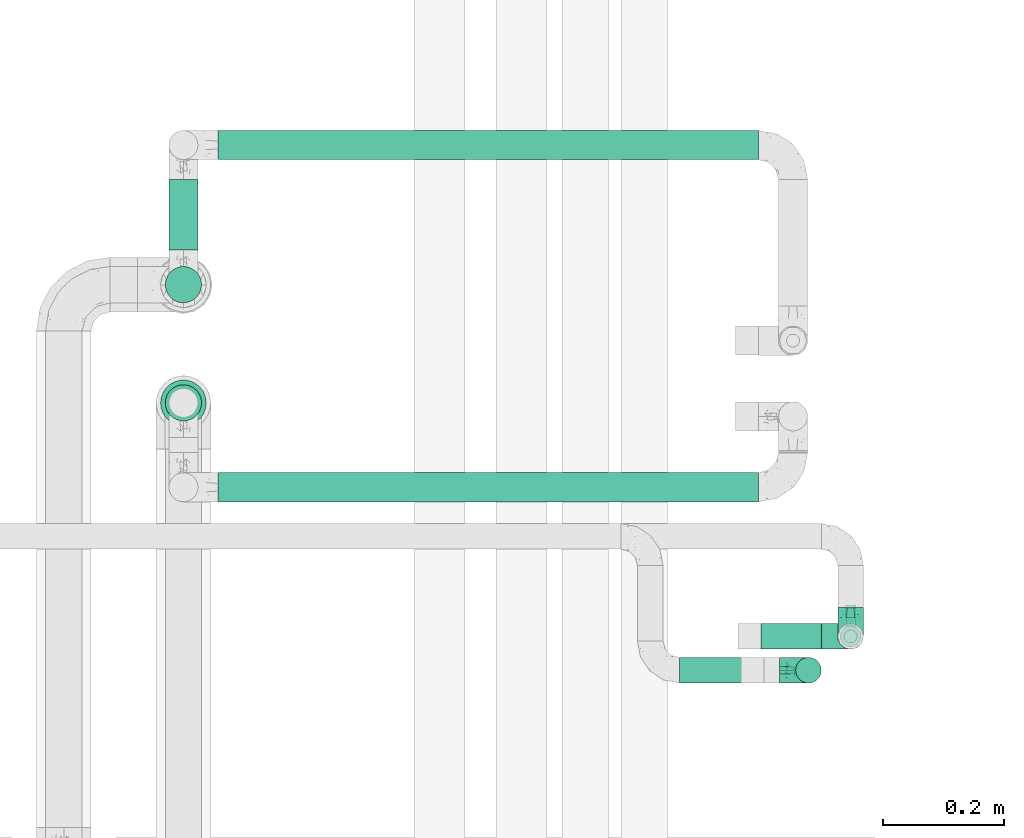
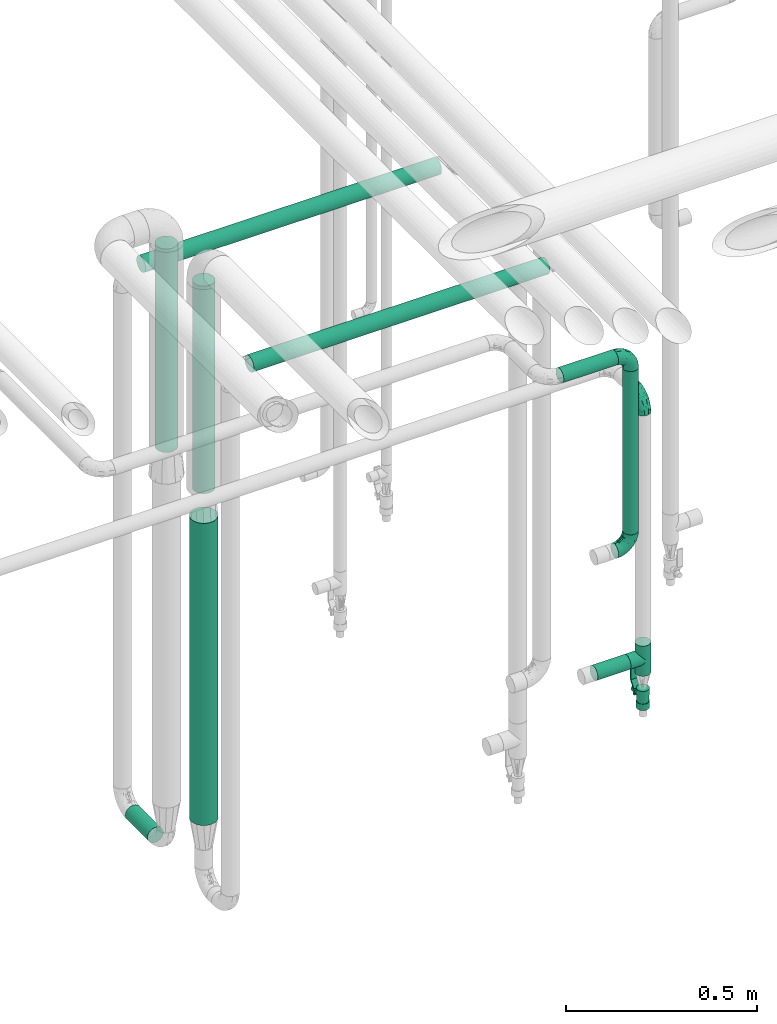
# One storey, part 575 of 827: 9 flow segments, 4 flow fittings, 1 flow controller.
"""IFC2X3 building model written with IfcOpenShell, lengths in millimetres."""

from ifc_helpers import new_model, entity, si_unit, converted_unit, derived_unit, direction, frame, origin, origin_2d_with_axis, place, context, subcontext, project, spatial, polyline, circle, outline, extrude, faceted_brep, source, transform, mapped, material, material_list, type_object, type_shapes, element, save


model = new_model("IFC2X3")

# Units and contexts
model_context = context("Model", 3, precision=0.01, world=origin(), true_north=direction((6.12303176911189e-17, 1.0)))
body_context = subcontext(model_context, "Body", "Model", "MODEL_VIEW")
ifc_project = project(units=[si_unit("LENGTHUNIT", "METRE", prefix="MILLI"), si_unit("AREAUNIT", "SQUARE_METRE"), si_unit("VOLUMEUNIT", "CUBIC_METRE"), converted_unit("PLANEANGLEUNIT", "DEGREE", entity("IfcRatioMeasure", 0.0174532925199433), si_unit("PLANEANGLEUNIT", "RADIAN"), dimensions=[0, 0, 0, 0, 0, 0, 0]), si_unit("MASSUNIT", "GRAM", prefix="KILO"), derived_unit("MASSDENSITYUNIT", [(si_unit("MASSUNIT", "GRAM", prefix="KILO"), 1), (si_unit("LENGTHUNIT", "METRE"), -3)]), derived_unit("MOMENTOFINERTIAUNIT", [(si_unit("LENGTHUNIT", "METRE"), 4)]), si_unit("TIMEUNIT", "SECOND"), si_unit("FREQUENCYUNIT", "HERTZ"), si_unit("THERMODYNAMICTEMPERATUREUNIT", "DEGREE_CELSIUS"), derived_unit("THERMALTRANSMITTANCEUNIT", [(si_unit("MASSUNIT", "GRAM", prefix="KILO"), 1), (si_unit("THERMODYNAMICTEMPERATUREUNIT", "KELVIN"), -1), (si_unit("TIMEUNIT", "SECOND"), -3)]), derived_unit("VOLUMETRICFLOWRATEUNIT", [(si_unit("LENGTHUNIT", "METRE"), 3), (si_unit("TIMEUNIT", "SECOND"), -1)]), derived_unit("MASSFLOWRATEUNIT", [(si_unit("MASSUNIT", "GRAM", prefix="KILO"), 1), (si_unit("TIMEUNIT", "SECOND"), -1)]), derived_unit("ROTATIONALFREQUENCYUNIT", [(si_unit("TIMEUNIT", "SECOND"), -1)]), si_unit("ELECTRICCURRENTUNIT", "AMPERE"), si_unit("ELECTRICVOLTAGEUNIT", "VOLT"), si_unit("POWERUNIT", "WATT"), si_unit("FORCEUNIT", "NEWTON", prefix="KILO"), si_unit("ILLUMINANCEUNIT", "LUX"), si_unit("LUMINOUSFLUXUNIT", "LUMEN"), si_unit("LUMINOUSINTENSITYUNIT", "CANDELA"), derived_unit("USERDEFINED", [(si_unit("MASSUNIT", "GRAM", prefix="KILO"), -1), (si_unit("LENGTHUNIT", "METRE"), -2), (si_unit("TIMEUNIT", "SECOND"), 3), (si_unit("LUMINOUSFLUXUNIT", "LUMEN"), 1)]), derived_unit("LINEARVELOCITYUNIT", [(si_unit("LENGTHUNIT", "METRE"), 1), (si_unit("TIMEUNIT", "SECOND"), -1)]), si_unit("PRESSUREUNIT", "PASCAL"), derived_unit("USERDEFINED", [(si_unit("LENGTHUNIT", "METRE"), -2), (si_unit("MASSUNIT", "GRAM", prefix="KILO"), 1), (si_unit("TIMEUNIT", "SECOND"), -2)]), derived_unit("LINEARFORCEUNIT", [(si_unit("MASSUNIT", "GRAM", prefix="KILO"), 1), (si_unit("LENGTHUNIT", "METRE"), 1), (si_unit("TIMEUNIT", "SECOND"), -2), (si_unit("LENGTHUNIT", "METRE"), -1)]), derived_unit("PLANARFORCEUNIT", [(si_unit("MASSUNIT", "GRAM", prefix="KILO"), 1), (si_unit("LENGTHUNIT", "METRE"), 1), (si_unit("TIMEUNIT", "SECOND"), -2), (si_unit("LENGTHUNIT", "METRE"), -2)])], contexts=[model_context])

# Site, building, storey
site_placement = place(None, origin())
site = spatial("IfcSite", under=ifc_project, at=site_placement, CompositionType="ELEMENT")
building_placement = place(site_placement, origin())
building = spatial("IfcBuilding", under=site, at=building_placement, CompositionType="ELEMENT")
storey_placement = place(building_placement, frame((0.0, 0.0, 28200.0)))
storey = spatial("IfcBuildingStorey", under=building, at=storey_placement, Name="08", CompositionType="ELEMENT", Elevation=28200.0)

# Flow segments
pipe_segment_type = type_object("IfcPipeSegmentType", PredefinedType="NOTDEFINED")
flow_segment_1_placement = place(storey_placement, frame((18741.2, 15063.0, 1977.25)))
element("IfcFlowSegment", 1, at=flow_segment_1_placement, inside=storey, type_object=pipe_segment_type, context=body_context, shape_type="SweptSolid", body=[
    extrude(circle(Radius=21.15, at=origin_2d_with_axis()), frame((0.0, 22.75, 22.75), z_axis=(1.0, 0.0, 0.0), x_axis=(0.0, -1.0, 0.0)), (0.0, 0.0, 1.0), 165.253426009053),
])
flow_segment_2_placement = place(storey_placement, frame((17890.7, 15495.65, 1662.32)))
element("IfcFlowSegment", 2, at=flow_segment_2_placement, inside=storey, type_object=pipe_segment_type, context=body_context, shape_type="SweptSolid", body=[
    extrude(circle(Radius=30.0, at=origin_2d_with_axis()), frame((31.6, 31.6, 0.0)), (0.0, 0.0, 1.0), 661.683633817541),
])
flow_segment_3_placement = place(storey_placement, frame((17890.7, 15690.85, 1675.32)))
element("IfcFlowSegment", 3, at=flow_segment_3_placement, inside=storey, type_object=pipe_segment_type, context=body_context, shape_type="SweptSolid", body=[
    extrude(circle(Radius=30.0, at=origin_2d_with_axis()), frame((31.6, 31.6, 0.0)), (0.0, 0.0, 1.0), 648.839896833194),
])
flow_segment_4_placement = place(storey_placement, frame((17896.7, 15779.44, 375.34)))
element("IfcFlowSegment", 4, at=flow_segment_4_placement, inside=storey, type_object=pipe_segment_type, context=body_context, shape_type="SweptSolid", body=[
    extrude(circle(Radius=24.0, at=origin_2d_with_axis()), frame((25.6, 0.0, 25.6), z_axis=(0.0, 1.0, 0.0), x_axis=(-1.0, 0.0, 0.0)), (0.0, 0.0, 1.0), 116.645270208734),
])
flow_segment_5_placement = place(storey_placement, frame((17979.29, 15927.49, 2070.34)))
element("IfcFlowSegment", 5, at=flow_segment_5_placement, inside=storey, type_object=pipe_segment_type, context=body_context, shape_type="SweptSolid", body=[
    extrude(circle(Radius=24.0, at=origin_2d_with_axis()), frame((0.0, 25.6, 25.6), z_axis=(1.0, 0.0, 0.0), x_axis=(0.0, -1.0, 0.0)), (0.0, 0.0, 1.0), 892.764504538315),
])
flow_segment_6_placement = place(storey_placement, frame((17979.29, 15362.39, 2095.34)))
element("IfcFlowSegment", 6, at=flow_segment_6_placement, inside=storey, type_object=pipe_segment_type, context=body_context, shape_type="SweptSolid", body=[
    extrude(circle(Radius=24.0, at=origin_2d_with_axis()), frame((0.0, 25.6, 25.6), z_axis=(1.0, 0.0, 0.0), x_axis=(0.0, -1.0, 0.0)), (0.0, 0.0, 1.0), 892.764504538304),
])
flow_segment_7_placement = place(storey_placement, frame((17882.95, 15487.9, 609.94)))
element("IfcFlowSegment", 7, at=flow_segment_7_placement, inside=storey, type_object=pipe_segment_type, context=body_context, shape_type="SweptSolid", body=[
    extrude(circle(Radius=37.75, at=origin_2d_with_axis()), frame((39.35, 39.35, 0.0), z_axis=(0.0, 0.0, 1.0), x_axis=(-1.0, 0.0, 0.0)), (0.0, 0.0, 1.0), 963.376941605387),
])
flow_segment_8_placement = place(storey_placement, frame((18931.71, 15063.0, 1431.37)))
element("IfcFlowSegment", 8, at=flow_segment_8_placement, inside=storey, type_object=pipe_segment_type, context=body_context, shape_type="SweptSolid", body=[
    extrude(circle(Radius=21.15, at=origin_2d_with_axis()), frame((22.75, 22.75, 0.0), z_axis=(0.0, 0.0, 1.0), x_axis=(-1.0, 0.0, 0.0)), (0.0, 0.0, 1.0), 520.625971677545),
])
flow_segment_9_placement = place(storey_placement, frame((18876.06, 15119.04, 947.36)))
element("IfcFlowSegment", 9, at=flow_segment_9_placement, inside=storey, type_object=pipe_segment_type, context=body_context, shape_type="SweptSolid", body=[
    extrude(circle(Radius=21.15, at=origin_2d_with_axis()), frame((0.0, 22.75, 22.75), z_axis=(1.0, 0.0, 0.0), x_axis=(0.0, 1.0, 0.0)), (0.0, 0.0, 1.0), 100.000000000001),
])

# Flow controller
ifc_material = material()
ifc_material_list = material_list([ifc_material, ifc_material, ifc_material, ifc_material, ifc_material])
valve_type = type_object("IfcValveType", PredefinedType="NOTDEFINED", material=ifc_material_list)
shared_shape_1 = source(origin(), body_context, "Body", "SweptSolid", [
    extrude(circle(Radius=17.5, at=origin_2d_with_axis()), frame((-30.5, 0.0, 0.0), z_axis=(1.0, 0.0, 0.0), x_axis=(0.0, 1.0, 0.0)), (0.0, 0.0, 1.0), 20.3333333333333),
    extrude(circle(Radius=16.0, at=origin_2d_with_axis()), frame((-10.17, 0.0, 0.0), z_axis=(1.0, 0.0, 0.0), x_axis=(0.0, 1.0, 0.0)), (0.0, 0.0, 1.0), 20.3333333333333),
    extrude(circle(Radius=17.5, at=origin_2d_with_axis()), frame((10.17, 0.0, 0.0), z_axis=(1.0, 0.0, 0.0), x_axis=(0.0, 1.0, 0.0)), (0.0, 0.0, 1.0), 20.3333333333333),
    extrude(outline(polyline([(-38.75, -5.0), (-38.75, -10.0), (-17.92, -10.0), (2.08, 5.0), (56.25, 5.0), (56.25, 10.0), (0.42, 10.0), (-19.58, -5.0), (-38.75, -5.0)])), frame((28.75, -8.75, 41.5), z_axis=(0.0, -1.0, 0.0), x_axis=(1.0, 0.0, 0.0)), (0.0, 0.0, -1.0), 17.5),
    extrude(circle(Radius=8.0, at=origin_2d_with_axis()), origin(), (0.0, 0.0, 1.0), 49.0),
])
type_shapes(valve_type, [shared_shape_1])
flow_controller_placement = place(storey_placement, frame((19024.06, 15141.79, 840.61), z_axis=(0.0, 1.0, 0.0), x_axis=(0.0, 0.0, 1.0)))
element("IfcFlowController", 10, at=flow_controller_placement, inside=storey, type_object=valve_type, material=ifc_material, context=body_context, shape_type="MappedRepresentation", body=[
    mapped(shared_shape_1, transform((0.0, 0.0, 0.0), scale=1.0)),
])

# Flow fittings
pipe_fitting_type_1 = type_object("IfcPipeFittingType", Name="ADSK_1", PredefinedType="NOTDEFINED", material=ifc_material)
shared_shape_2 = source(origin(), body_context, "Body", "Brep", [
    faceted_brep([(-48.0, 10.6, -18.36), (-48.0, 5.49, -20.48), (-48.0, 0.0, -21.2), (-48.0, -5.49, -20.48), (-48.0, -10.6, -18.36), (-48.0, -14.99, -14.99), (-48.0, -18.36, -10.6), (-48.0, -20.48, -5.49), (-48.0, -21.2, 0.0), (-48.0, -20.48, 5.49), (-48.0, -18.36, 10.6), (-48.0, -14.99, 14.99), (-48.0, -10.6, 18.36), (-48.0, -5.49, 20.48), (-48.0, 0.0, 21.2), (-48.0, 5.49, 20.48), (-48.0, 10.6, 18.36), (-48.0, 14.99, 14.99), (-48.0, 18.36, 10.6), (-48.0, 20.48, 5.49), (-48.0, 21.2, 0.0), (-48.0, 20.48, -5.49), (-48.0, 18.36, -10.6), (-48.0, 14.99, -14.99), (0.0, 48.0, -21.2), (-5.49, 48.0, -20.48), (-10.6, 48.0, -18.36), (-14.99, 48.0, -14.99), (-18.36, 48.0, -10.6), (-20.48, 48.0, -5.49), (-21.2, 48.0, 0.0), (-20.48, 48.0, 5.49), (-18.36, 48.0, 10.6), (-14.99, 48.0, 14.99), (-10.6, 48.0, 18.36), (-5.49, 48.0, 20.48), (0.0, 48.0, 21.2), (5.49, 48.0, 20.48), (10.6, 48.0, 18.36), (14.99, 48.0, 14.99), (18.36, 48.0, 10.6), (20.48, 48.0, 5.49), (21.2, 48.0, 0.0), (20.48, 48.0, -5.49), (18.36, 48.0, -10.6), (14.99, 48.0, -14.99), (10.6, 48.0, -18.36), (5.49, 48.0, -20.48), (-35.25, -16.22, 12.01), (-34.76, -18.57, 0.0), (-20.87, -12.37, 10.9), (-31.49, -11.78, 15.9), (-37.0, -2.58, 20.86), (-33.89, 3.62, 21.15), (-31.81, -18.14, 6.76), (-5.78, 5.78, 17.67), (-19.42, -4.1, 17.86), (-9.6, -3.39, 13.73), (-35.44, -7.73, 19.13), (11.78, 31.49, 15.9), (-5.93, -5.46, 6.95), (-18.45, -13.78, 5.46), (-10.29, -8.43, 0.0), (-24.6, 0.55, 20.62), (-37.28, 17.94, 13.81), (-33.38, 22.85, 9.59), (-41.46, 20.06, 8.75), (-29.51, 20.45, 15.16), (-15.04, 10.79, 21.13), (-7.08, 16.98, 20.93), (-8.39, 23.51, 21.15), (-40.86, 13.03, 17.26), (-8.05, 41.26, 19.83), (-3.21, 35.97, 21.14), (8.53, 19.66, 14.74), (4.1, 19.42, 17.86), (-37.72, 22.66, 4.78), (-37.07, 8.58, 19.98), (-13.0, 5.43, 19.97), (-3.78, 13.93, 19.7), (3.02, 8.69, 13.43), (-2.27, -0.05, 10.65), (6.22, 6.99, 7.09), (-22.25, 34.6, 9.45), (18.14, 31.81, 6.76), (16.22, 35.25, 12.01), (12.37, 20.87, 10.9), (7.73, 35.44, 19.13), (-21.52, -15.93, 0.0), (2.58, 37.0, 20.86), (18.57, 34.76, 0.0), (13.78, 18.45, 5.46), (15.93, 21.52, 0.0), (-20.03, -8.54, 14.9), (-28.6, 28.6, 5.16), (-24.79, 34.6, 0.0), (-34.6, 24.79, 0.0), (-22.81, 37.41, 4.68), (-23.36, 26.33, 14.79), (-13.68, 37.05, 17.49), (-17.72, 38.12, 13.73), (-26.25, 27.3, 11.24), (-9.71, 32.34, 20.14), (-17.26, 25.6, 18.71), (-26.33, 9.99, 20.77), (-24.06, 6.05, 21.2), (-25.02, 15.46, 19.56), (-24.3, 20.72, 17.57), (-31.95, 15.23, 17.8), (-13.53, 24.7, 20.21), (-17.6, 17.6, 20.6), (-0.55, 24.6, 20.62), (-11.41, -7.48, 10.43), (0.93, -0.93, 0.0), (8.43, 10.29, 0.0), (-11.41, -7.48, -10.43), (-20.1, -8.84, -14.66), (-9.6, -3.39, -13.73), (7.73, 35.44, -19.13), (4.1, 19.42, -17.86), (-0.55, 24.6, -20.62), (-38.12, 17.72, -13.73), (-37.05, 13.68, -17.49), (-32.34, 9.71, -20.14), (-41.26, 8.05, -19.83), (-37.41, 22.81, -4.68), (-23.51, 8.39, -21.15), (-35.97, 3.21, -21.14), (-28.6, 28.6, -5.16), (-31.81, -18.14, -6.76), (-18.45, -13.78, -5.46), (-25.6, 17.26, -18.71), (-19.42, -4.1, -17.86), (-17.94, 37.28, -13.81), (-22.85, 33.38, -9.59), (-20.06, 41.46, -8.75), (-31.49, -11.78, -15.9), (-35.25, -16.22, -12.01), (8.53, 19.66, -14.74), (11.78, 31.49, -15.9), (-9.99, 26.33, -20.77), (-6.05, 24.06, -21.2), (-10.79, 15.04, -21.13), (-37.0, -2.58, -20.86), (-16.98, 7.08, -20.93), (-5.43, 13.0, -19.97), (-13.93, 3.78, -19.7), (-20.87, -12.37, -10.9), (-26.33, 23.36, -14.79), (-22.66, 37.72, -4.78), (13.78, 18.45, -5.46), (18.14, 31.81, -6.76), (-15.46, 25.02, -19.56), (-20.72, 24.3, -17.57), (16.22, 35.25, -12.01), (-13.03, 40.86, -17.26), (-8.58, 37.07, -19.98), (2.58, 37.0, -20.86), (-3.62, 33.89, -21.15), (-34.6, 22.25, -9.45), (6.22, 6.99, -7.09), (-20.45, 29.51, -15.16), (-35.44, -7.73, -19.13), (12.37, 20.87, -10.9), (-27.3, 26.25, -11.24), (-15.23, 31.95, -17.8), (-24.7, 13.53, -20.21), (-24.6, 0.55, -20.62), (-5.78, 5.78, -17.67), (-17.6, 17.6, -20.6), (3.02, 8.69, -13.43), (-5.93, -5.46, -6.95), (-2.27, -0.05, -10.65)], [[[0, 1, 2, 3, 4, 5, 6, 7, 8, 9, 10, 11, 12, 13, 14, 15, 16, 17, 18, 19, 20, 21, 22, 23]], [[24, 25, 26, 27, 28, 29, 30, 31, 32, 33, 34, 35, 36, 37, 38, 39, 40, 41, 42, 43, 44, 45, 46, 47]], [[10, 48, 11]], [[9, 8, 49]], [[48, 50, 51]], [[14, 52, 53]], [[10, 54, 48]], [[9, 54, 10]], [[55, 56, 57]], [[51, 12, 11]], [[51, 58, 12]], [[59, 39, 38]], [[60, 61, 62]], [[58, 56, 63]], [[64, 65, 66]], [[67, 65, 64]], [[68, 69, 70]], [[16, 71, 17]], [[13, 52, 14]], [[35, 72, 73]], [[14, 53, 15]], [[17, 64, 18]], [[74, 59, 75]], [[20, 19, 76]], [[66, 19, 18]], [[77, 15, 53]], [[15, 77, 16]], [[69, 78, 79]], [[80, 81, 82]], [[32, 31, 83]], [[84, 85, 86]], [[59, 87, 75]], [[61, 54, 88]], [[36, 89, 37]], [[84, 41, 40]], [[36, 35, 73]], [[90, 41, 84]], [[40, 39, 85]], [[12, 58, 13]], [[85, 84, 40]], [[91, 84, 86]], [[84, 92, 90]], [[87, 38, 37]], [[93, 56, 51]], [[65, 94, 76]], [[94, 95, 96]], [[84, 91, 92]], [[95, 97, 30]], [[98, 99, 100]], [[76, 94, 96]], [[101, 98, 83]], [[100, 99, 33]], [[102, 70, 73]], [[103, 102, 99]], [[94, 97, 95]], [[72, 99, 102]], [[72, 35, 34]], [[34, 33, 99]], [[9, 49, 54]], [[87, 59, 38]], [[104, 105, 68]], [[106, 103, 107]], [[106, 77, 104]], [[71, 64, 17]], [[108, 107, 67]], [[33, 32, 100]], [[109, 103, 110]], [[102, 109, 70]], [[89, 73, 111]], [[50, 48, 54]], [[51, 11, 48]], [[56, 58, 51]], [[88, 54, 49]], [[52, 58, 63]], [[50, 112, 93]], [[56, 55, 78]], [[39, 59, 85]], [[86, 85, 59]], [[89, 87, 37]], [[42, 41, 90]], [[111, 79, 75]], [[111, 75, 87]], [[75, 55, 80]], [[104, 77, 53]], [[71, 77, 108]], [[32, 83, 100]], [[98, 100, 83]], [[99, 98, 103]], [[106, 107, 108]], [[68, 70, 110]], [[111, 73, 70]], [[68, 110, 104]], [[68, 63, 78]], [[57, 93, 112]], [[80, 55, 57]], [[61, 50, 54]], [[80, 82, 86]], [[81, 57, 112]], [[74, 86, 59]], [[60, 113, 82]], [[82, 114, 91]], [[101, 94, 65]], [[97, 94, 83]], [[73, 89, 36]], [[87, 89, 111]], [[58, 52, 13]], [[53, 52, 63]], [[104, 53, 105]], [[106, 104, 110]], [[20, 76, 96]], [[76, 19, 66]], [[103, 106, 110]], [[77, 106, 108]], [[103, 98, 107]], [[67, 107, 98]], [[67, 98, 101]], [[108, 67, 64]], [[53, 63, 105]], [[63, 68, 105]], [[83, 31, 97]], [[30, 97, 31]], [[62, 113, 60]], [[112, 61, 60]], [[61, 88, 62]], [[86, 82, 91]], [[56, 78, 63]], [[114, 82, 113]], [[114, 92, 91]], [[79, 78, 55]], [[75, 79, 55]], [[69, 79, 111]], [[70, 69, 111]], [[78, 69, 68]], [[77, 71, 16]], [[64, 71, 108]], [[64, 66, 18]], [[76, 66, 65]], [[99, 72, 34]], [[73, 72, 102]], [[94, 101, 83]], [[67, 101, 65]], [[75, 80, 74]], [[80, 86, 74]], [[70, 109, 110]], [[102, 103, 109]], [[50, 93, 51]], [[57, 56, 93]], [[61, 112, 50]], [[81, 112, 60]], [[82, 81, 60]], [[80, 57, 81]], [[115, 116, 117]], [[118, 119, 120]], [[121, 122, 23]], [[123, 124, 122]], [[96, 125, 20]], [[123, 126, 127]], [[128, 96, 95]], [[129, 130, 88]], [[123, 122, 131]], [[116, 132, 117]], [[133, 134, 135]], [[0, 124, 1]], [[5, 136, 137]], [[138, 119, 139]], [[129, 88, 49]], [[140, 141, 142]], [[6, 5, 137]], [[46, 118, 47]], [[143, 3, 2]], [[144, 145, 146]], [[6, 129, 7]], [[129, 137, 147]], [[127, 2, 1]], [[148, 122, 121]], [[128, 125, 96]], [[134, 128, 149]], [[95, 149, 128]], [[150, 151, 92]], [[30, 29, 149]], [[152, 131, 153]], [[27, 133, 28]], [[154, 45, 44]], [[136, 5, 4]], [[27, 26, 155]], [[156, 26, 25]], [[24, 157, 158]], [[24, 47, 157]], [[22, 21, 159]], [[160, 150, 114]], [[134, 133, 161]], [[142, 144, 126]], [[46, 139, 118]], [[162, 136, 4]], [[156, 25, 158]], [[1, 124, 127]], [[115, 147, 116]], [[45, 154, 139]], [[139, 46, 45]], [[154, 163, 139]], [[162, 4, 3]], [[42, 90, 43]], [[130, 129, 147]], [[49, 7, 129]], [[43, 151, 44]], [[0, 23, 122]], [[24, 158, 25]], [[136, 162, 132]], [[135, 29, 28]], [[43, 90, 151]], [[164, 148, 159]], [[152, 156, 140]], [[155, 133, 27]], [[165, 153, 161]], [[23, 22, 121]], [[123, 131, 166]], [[123, 166, 126]], [[143, 127, 167]], [[147, 137, 136]], [[8, 7, 49]], [[129, 6, 137]], [[143, 162, 3]], [[167, 146, 132]], [[167, 132, 162]], [[132, 168, 117]], [[44, 151, 154]], [[92, 151, 90]], [[163, 154, 151]], [[119, 118, 139]], [[157, 118, 120]], [[138, 139, 163]], [[119, 168, 145]], [[140, 156, 158]], [[155, 156, 165]], [[22, 159, 121]], [[148, 121, 159]], [[122, 148, 131]], [[152, 153, 165]], [[142, 126, 169]], [[167, 127, 126]], [[142, 169, 140]], [[142, 120, 145]], [[168, 170, 117]], [[160, 171, 172]], [[115, 172, 171]], [[171, 62, 130]], [[119, 170, 168]], [[170, 163, 160]], [[150, 163, 151]], [[113, 171, 160]], [[164, 128, 134]], [[125, 128, 159]], [[127, 143, 2]], [[162, 143, 167]], [[118, 157, 47]], [[158, 157, 120]], [[140, 158, 141]], [[152, 140, 169]], [[30, 149, 95]], [[149, 29, 135]], [[131, 152, 169]], [[156, 152, 165]], [[131, 148, 153]], [[161, 153, 148]], [[161, 148, 164]], [[165, 161, 133]], [[158, 120, 141]], [[120, 142, 141]], [[159, 21, 125]], [[20, 125, 21]], [[115, 130, 147]], [[114, 113, 160]], [[62, 171, 113]], [[62, 88, 130]], [[160, 163, 150]], [[150, 92, 114]], [[119, 145, 120]], [[146, 145, 168]], [[132, 146, 168]], [[144, 146, 167]], [[126, 144, 167]], [[145, 144, 142]], [[156, 155, 26]], [[133, 155, 165]], [[133, 135, 28]], [[149, 135, 134]], [[122, 124, 0]], [[127, 124, 123]], [[128, 164, 159]], [[161, 164, 134]], [[163, 170, 138]], [[170, 119, 138]], [[131, 169, 166]], [[126, 166, 169]], [[147, 136, 116]], [[132, 116, 136]], [[172, 115, 117]], [[130, 115, 171]], [[117, 170, 172]], [[160, 172, 170]]]),
])
type_shapes(pipe_fitting_type_1, [shared_shape_2])
for number, where, z_axis, x_axis, name in (
    (11, (19024.06, 15141.79, 1800.0), (1.0, 0.0, 0.0), (0.0, -1.0, 0.0), "ADSK_1"),
    (12, (18954.46, 15085.74, 1383.37), (0.0, -1.0, 0.0), (1.0, 0.0, 0.0), "ADSK_1"),
    (13, (18954.46, 15085.74, 2000.0), (0.0, -1.0, 0.0), (0.0, 0.0, 1.0), "ADSK_1"),
):
    element("IfcFlowFitting", number, at=place(storey_placement, frame(where, z_axis=z_axis, x_axis=x_axis)), inside=storey, type_object=pipe_fitting_type_1, material=ifc_material, Name=name, ObjectType="ADSK_1", context=body_context, shape_type="MappedRepresentation", body=[
        mapped(shared_shape_2, transform((0.0, 0.0, 0.0), scale=1.0)),
    ])
pipe_fitting_type_2 = type_object("IfcPipeFittingType", Name="ADSK_1", PredefinedType="NOTDEFINED", material=ifc_material)
shared_shape_3 = source(origin(), body_context, "Body", "Brep", [
    faceted_brep([(-48.0, 10.6, -18.36), (-48.0, 5.49, -20.48), (-48.0, 0.0, -21.2), (-48.0, -5.49, -20.48), (-48.0, -10.6, -18.36), (-48.0, -14.99, -14.99), (-48.0, -18.36, -10.6), (-48.0, -20.48, -5.49), (-48.0, -21.2, 0.0), (-48.0, -20.48, 5.49), (-48.0, -18.36, 10.6), (-48.0, -14.99, 14.99), (-48.0, -10.6, 18.36), (-48.0, -5.49, 20.48), (-48.0, 0.0, 21.2), (-48.0, 5.49, 20.48), (-48.0, 10.6, 18.36), (-48.0, 14.99, 14.99), (-48.0, 18.36, 10.6), (-48.0, 20.48, 5.49), (-48.0, 21.2, 0.0), (-48.0, 20.48, -5.49), (-48.0, 18.36, -10.6), (-48.0, 14.99, -14.99), (48.0, 0.0, -21.2), (48.0, 5.49, -20.48), (48.0, 10.6, -18.36), (48.0, 14.99, -14.99), (48.0, 18.36, -10.6), (48.0, 20.48, -5.49), (48.0, 21.2, 0.0), (48.0, 20.48, 5.49), (48.0, 18.36, 10.6), (48.0, 14.99, 14.99), (48.0, 10.6, 18.36), (48.0, 5.49, 20.48), (48.0, 0.0, 21.2), (48.0, -5.49, 20.48), (48.0, -10.6, 18.36), (48.0, -14.99, 14.99), (48.0, -18.36, 10.6), (48.0, -20.48, 5.49), (48.0, -21.2, 0.0), (48.0, -20.48, -5.49), (48.0, -18.36, -10.6), (48.0, -14.99, -14.99), (48.0, -10.6, -18.36), (48.0, -5.49, -20.48), (20.43, -20.43, 5.66), (21.2, -21.2, 0.0), (-21.2, -21.2, 0.0), (18.35, -18.35, 10.62), (11.88, -11.88, 17.56), (15.38, -15.38, 14.59), (-20.43, -20.43, 5.66), (-18.35, -18.35, 10.62), (-15.38, -15.38, 14.59), (-11.88, -11.88, 17.56), (-8.06, -8.06, 19.61), (8.06, -8.06, 19.61), (4.07, -4.07, 20.81), (0.0, 0.0, 21.2), (-4.07, -4.07, 20.81), (4.07, -4.07, -20.81), (0.0, 0.0, -21.2), (-4.07, -4.07, -20.81), (-8.06, -8.06, -19.61), (8.06, -8.06, -19.61), (11.88, -11.88, -17.56), (15.38, -15.38, -14.59), (18.35, -18.35, -10.62), (20.43, -20.43, -5.66), (-11.88, -11.88, -17.56), (-15.38, -15.38, -14.59), (-20.43, -20.43, -5.66), (-18.35, -18.35, -10.62), (0.0, -48.0, -21.2), (5.49, -48.0, -20.48), (10.6, -48.0, -18.36), (14.99, -48.0, -14.99), (18.36, -48.0, -10.6), (20.48, -48.0, -5.49), (21.2, -48.0, 0.0), (20.48, -48.0, 5.49), (18.36, -48.0, 10.6), (14.99, -48.0, 14.99), (10.6, -48.0, 18.36), (5.49, -48.0, 20.48), (0.0, -48.0, 21.2), (-5.49, -48.0, 20.48), (-10.6, -48.0, 18.36), (-14.99, -48.0, 14.99), (-18.36, -48.0, 10.6), (-20.48, -48.0, 5.49), (-21.2, -48.0, 0.0), (-20.48, -48.0, -5.49), (-18.36, -48.0, -10.6), (-14.99, -48.0, -14.99), (-10.6, -48.0, -18.36), (-5.49, -48.0, -20.48)], [[[0, 1, 2, 3, 4, 5, 6, 7, 8, 9, 10, 11, 12, 13, 14, 15, 16, 17, 18, 19, 20, 21, 22, 23]], [[24, 25, 26, 27, 28, 29, 30, 31, 32, 33, 34, 35, 36, 37, 38, 39, 40, 41, 42, 43, 44, 45, 46, 47]], [[41, 40, 48]], [[42, 41, 49]], [[50, 9, 8]], [[49, 41, 48]], [[40, 51, 48]], [[39, 38, 52]], [[51, 40, 53]], [[52, 53, 39]], [[53, 40, 39]], [[50, 54, 9]], [[9, 54, 10]], [[54, 55, 10]], [[56, 57, 11]], [[11, 10, 56]], [[11, 57, 12]], [[56, 10, 55]], [[12, 57, 58]], [[52, 38, 59]], [[60, 36, 61]], [[62, 61, 14]], [[59, 37, 60]], [[37, 59, 38]], [[60, 37, 36]], [[61, 36, 35, 15, 14]], [[32, 31, 19, 18]], [[17, 16, 34, 33]], [[18, 17, 33, 32]], [[35, 34, 16, 15]], [[20, 19, 31, 30]], [[62, 13, 58]], [[13, 62, 14]], [[58, 13, 12]], [[27, 23, 22, 28]], [[22, 21, 29, 28]], [[0, 23, 27, 26]], [[20, 30, 29, 21]], [[24, 47, 63]], [[24, 64, 2, 1, 25]], [[64, 24, 63]], [[2, 64, 65]], [[26, 25, 1, 0]], [[65, 66, 3]], [[2, 65, 3]], [[66, 4, 3]], [[63, 47, 67]], [[46, 45, 68]], [[69, 68, 45]], [[44, 70, 69]], [[69, 45, 44]], [[46, 68, 67]], [[43, 42, 49]], [[7, 50, 8]], [[43, 71, 44]], [[71, 43, 49]], [[44, 71, 70]], [[72, 4, 66]], [[72, 5, 4]], [[5, 72, 73]], [[5, 73, 6]], [[74, 50, 7]], [[75, 74, 6]], [[74, 7, 6]], [[75, 6, 73]], [[46, 67, 47]], [[76, 77, 78, 79, 80, 81, 82, 83, 84, 85, 86, 87, 88, 89, 90, 91, 92, 93, 94, 95, 96, 97, 98, 99]], [[50, 94, 93]], [[54, 50, 93]], [[91, 90, 57]], [[56, 92, 91]], [[54, 93, 92]], [[58, 90, 89]], [[55, 54, 92]], [[56, 55, 92]], [[58, 57, 90]], [[88, 61, 62]], [[58, 89, 62]], [[56, 91, 57]], [[62, 89, 88]], [[60, 88, 87]], [[86, 59, 87]], [[84, 83, 48]], [[53, 85, 84]], [[52, 86, 85]], [[49, 83, 82]], [[59, 60, 87]], [[52, 59, 86]], [[49, 48, 83]], [[51, 53, 84]], [[48, 51, 84]], [[52, 85, 53]], [[88, 60, 61]], [[82, 81, 49]], [[71, 49, 81]], [[69, 80, 79]], [[79, 78, 68]], [[71, 81, 80]], [[67, 78, 77]], [[70, 71, 80]], [[69, 70, 80]], [[67, 68, 78]], [[76, 64, 63]], [[67, 77, 63]], [[69, 79, 68]], [[63, 77, 76]], [[65, 76, 99]], [[98, 66, 99]], [[96, 95, 74]], [[73, 97, 96]], [[72, 98, 97]], [[50, 95, 94]], [[66, 65, 99]], [[72, 66, 98]], [[50, 74, 95]], [[75, 73, 96]], [[74, 75, 96]], [[72, 97, 73]], [[76, 65, 64]]]),
])
type_shapes(pipe_fitting_type_2, [shared_shape_3])
flow_fitting_placement = place(storey_placement, frame((19024.06, 15141.79, 970.11), z_axis=(0.0, 1.0, 0.0), x_axis=(0.0, 0.0, 1.0)))
element("IfcFlowFitting", 14, at=flow_fitting_placement, inside=storey, type_object=pipe_fitting_type_2, material=ifc_material, Name="ADSK_1", ObjectType="ADSK_1", context=body_context, shape_type="MappedRepresentation", body=[
    mapped(shared_shape_3, transform((0.0, 0.0, 0.0), scale=1.0)),
])

save(model, "model.ifc")
